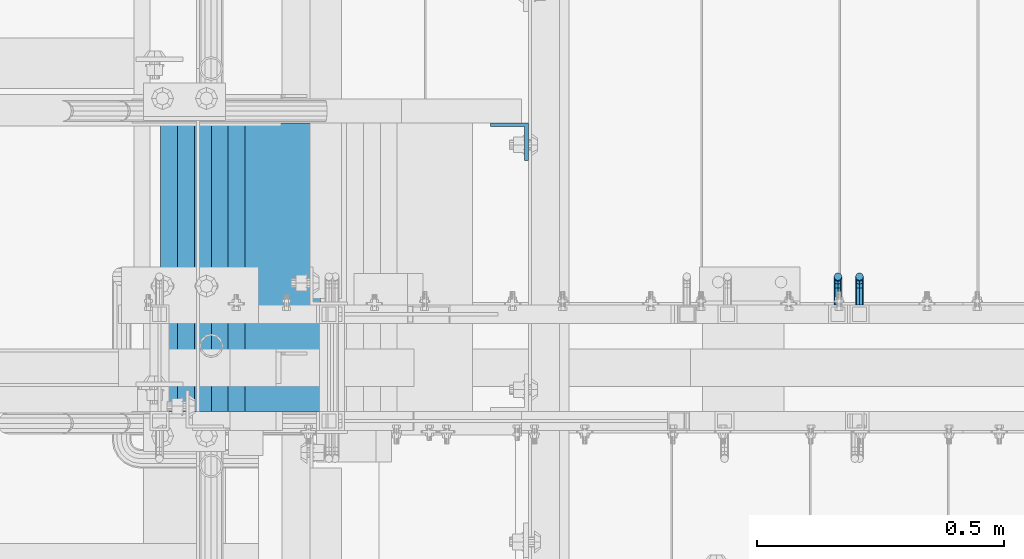
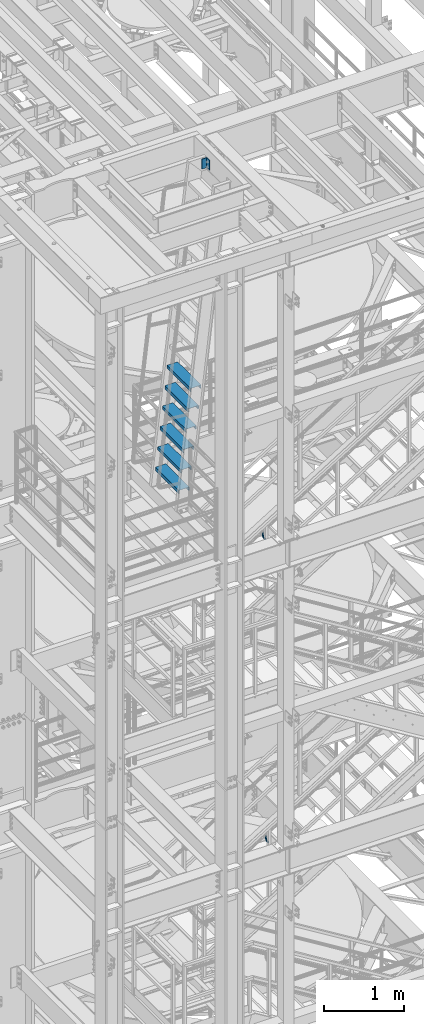
# One storey, part 1169 of 1876: 9 beams, 3 elements without a shape of their own.
"""IFC2X3 building model written with IfcOpenShell, lengths in millimetres."""

from ifc_helpers import new_model, si_unit, frame, origin_with_axes, place, context, subcontext, project, spatial, faceted_brep, material, type_object, element, aggregate, save


model = new_model("IFC2X3")

# Units and contexts
model_context = context("Model", 3, precision=1e-05, world=origin_with_axes())
body_context = subcontext(model_context, "Body", "Model", "MODEL_VIEW")
ifc_project = project(units=[si_unit("LENGTHUNIT", "METRE", prefix="MILLI"), si_unit("AREAUNIT", "SQUARE_METRE"), si_unit("VOLUMEUNIT", "CUBIC_METRE"), si_unit("MASSUNIT", "GRAM", prefix="KILO"), si_unit("TIMEUNIT", "SECOND"), si_unit("PLANEANGLEUNIT", "RADIAN"), si_unit("SOLIDANGLEUNIT", "STERADIAN"), si_unit("THERMODYNAMICTEMPERATUREUNIT", "DEGREE_CELSIUS"), si_unit("LUMINOUSINTENSITYUNIT", "LUMEN")], contexts=[model_context])

# Site, building, storey
site_placement = place(None, origin_with_axes())
site = spatial("IfcSite", under=ifc_project, at=site_placement, CompositionType="ELEMENT")
building_placement = place(site_placement, origin_with_axes())
building = spatial("IfcBuilding", under=site, at=building_placement, Name="Undefined", CompositionType="ELEMENT")
storey_placement = place(building_placement, origin_with_axes())
storey = spatial("IfcBuildingStorey", under=building, at=storey_placement, Name="Undefined", CompositionType="ELEMENT", Elevation=0.0)

# Assembly, beam
assembly_1_placement = place(storey_placement, origin_with_axes())
assembly_1 = element("IfcElementAssembly", 1, at=assembly_1_placement, inside=storey, Name="RAIL", AssemblyPlace="NOTDEFINED", PredefinedType="RIGID_FRAME")
ifc_material = material(Name="STEEL/A36")
beam_type_1 = type_object("IfcBeamType", PredefinedType="NOTDEFINED")
beam_1_placement = place(assembly_1_placement, frame((3092.45000026398, -5715.00000114554, 12296.9866319821), z_axis=(1.0, 0.0, 0.0), x_axis=(0.0, 1.0, 0.0)))
beam_1 = element("IfcBeam", 2, at=beam_1_placement, type_object=beam_type_1, material=ifc_material, Name="BRACKET", context=body_context, shape_type="Brep", body=[
    faceted_brep([(0.0, -5.61266007566822, 5.61266007566883), (0.0, 0.0, 7.9375), (0.0, 5.61266007566822, 5.61266007566883), (0.0, 7.9375, 0.0), (0.0, 5.61266007566822, -5.61266007566883), (0.0, 0.0, -7.9375), (0.0, -5.61266007566822, -5.61266007566883), (0.0, -7.9375, 0.0), (23.8125, -5.61266007566883, -5.61266007566792), (23.8125, -7.9375, 0.0), (23.8125, -5.61266007566883, 5.61266007566792), (23.8125, 0.0, 7.9375), (23.8125, 5.61266007566883, 5.61266007566792), (23.8125, 7.9375, 0.0), (23.8125, 5.61266007566883, -5.61266007566792), (23.8125, 0.0, -7.9375), (36.5702095103998, 2.53766620105671, -7.9375), (38.7180815328556, -2.64775556579843, -5.61266007566792), (39.6077592547981, -4.79562758825341, 0.0), (38.7180815328556, -2.64775556579843, 5.61266007566792), (36.5702095103998, 2.53766620105671, 7.9375), (34.4223374879448, 7.72308796790821, 5.61266007566792), (33.5326597660023, 9.87095999036319, 0.0), (34.4223374879448, 7.72308796790821, -5.61266007566792), (43.4169233967659, 13.733078129113, -5.61266007566792), (47.3856733967659, 9.76432812911298, -7.9375), (41.773013321098, 15.3769882047818, 0.0), (43.4169233967659, 13.733078129113, 5.61266007566792), (47.3856733967659, 9.76432812911298, 7.9375), (51.3544233967659, 5.79557812911298, 5.61266007566792), (52.9983334724348, 4.15166805344415, 0.0), (51.3544233967659, 5.79557812911298, -5.61266007566792), (54.6123353248231, 20.5797920154801, -7.9375), (59.7977570916764, 18.4319199930251, -5.61266007566792), (49.4269135579698, 22.727664037935, -5.61266007566792), (47.2790415355148, 23.6173417598766, 0.0), (49.4269135579698, 22.727664037935, 5.61266007566792), (54.6123353248231, 20.5797920154801, 7.9375), (59.7977570916764, 18.4319199930251, 5.61266007566792), (61.9456291141314, 17.5422422710835, 0.0), (62.7626616015468, 33.3375015258789, -5.61266007566792), (65.0875015258789, 33.3375015258789, 0.0), (57.1500015258789, 33.3375015258789, -7.9375), (51.5373414502101, 33.3375015258789, -5.61266007566792), (49.2125015258789, 33.3375015258789, 0.0), (51.5373414502101, 33.3375015258789, 5.61266007566792), (57.1500015258789, 33.3375015258789, 7.9375), (62.7626616015468, 33.3375015258789, 5.61266007566792), (65.0875015258789, 66.6490606416592, 0.0), (62.7626616015468, 70.1016967070464, 5.61266007566792), (57.1500015258789, 71.5318253912683, 7.9375), (51.537341450211, 70.1016967070464, 5.61266007566792), (49.2125015258789, 66.6490606416592, 0.0), (51.537341450211, 63.1964245762738, -5.61266007566792), (57.1500015258789, 61.7662958920519, -7.9375), (62.7626616015468, 63.1964245762738, -5.61266007566792)], [[[0, 1, 2, 3, 4, 5, 6, 7]], [[7, 6, 8, 9]], [[0, 7, 9, 10]], [[1, 0, 10, 11]], [[2, 1, 11, 12]], [[3, 2, 12, 13]], [[4, 3, 13, 14]], [[5, 4, 14, 15]], [[6, 5, 15, 8]], [[8, 15, 16, 17]], [[9, 8, 17, 18]], [[10, 9, 18, 19]], [[11, 10, 19, 20]], [[12, 11, 20, 21]], [[13, 12, 21, 22]], [[14, 13, 22, 23]], [[15, 14, 23, 16]], [[23, 24, 25, 16]], [[22, 26, 24, 23]], [[21, 27, 26, 22]], [[20, 28, 27, 21]], [[19, 29, 28, 20]], [[18, 30, 29, 19]], [[17, 31, 30, 18]], [[16, 25, 31, 17]], [[25, 32, 33, 31]], [[24, 34, 32, 25]], [[26, 35, 34, 24]], [[27, 36, 35, 26]], [[28, 37, 36, 27]], [[29, 38, 37, 28]], [[30, 39, 38, 29]], [[31, 33, 39, 30]], [[33, 40, 41, 39]], [[32, 42, 40, 33]], [[34, 43, 42, 32]], [[35, 44, 43, 34]], [[36, 45, 44, 35]], [[37, 46, 45, 36]], [[38, 47, 46, 37]], [[39, 41, 47, 38]], [[47, 41, 48, 49]], [[46, 47, 49, 50]], [[45, 46, 50, 51]], [[44, 45, 51, 52]], [[43, 44, 52, 53]], [[42, 43, 53, 54]], [[40, 42, 54, 55]], [[41, 40, 55, 48]], [[54, 53, 52, 51, 50, 49, 48, 55]]]),
])
aggregate(assembly_1, [beam_1])

assembly_2_placement = place(storey_placement, origin_with_axes())
assembly_2 = element("IfcElementAssembly", 3, at=assembly_2_placement, inside=storey, Name="RAIL", AssemblyPlace="NOTDEFINED", PredefinedType="RIGID_FRAME")
beam_2_placement = place(assembly_2_placement, frame((3048.79374922798, -5715.00000114554, 16930.3935489167), z_axis=(1.0, 0.0, 0.0), x_axis=(0.0, 1.0, 0.0)))
beam_2 = element("IfcBeam", 4, at=beam_2_placement, type_object=beam_type_1, material=ifc_material, Name="BRACKET", context=body_context, shape_type="Brep", body=[
    faceted_brep([(0.0, -5.61266007566822, 5.61266007566883), (0.0, 0.0, 7.9375), (0.0, 5.61266007566822, 5.61266007566883), (0.0, 7.9375, 0.0), (0.0, 5.61266007566822, -5.61266007566883), (0.0, 0.0, -7.9375), (0.0, -5.61266007566822, -5.61266007566883), (0.0, -7.9375, 0.0), (23.8125, -5.61266007566883, -5.61266007566792), (23.8125, -7.9375, 0.0), (23.8125, -5.61266007566883, 5.61266007566792), (23.8125, 0.0, 7.9375), (23.8125, 5.61266007566883, 5.61266007566792), (23.8125, 7.9375, 0.0), (23.8125, 5.61266007566883, -5.61266007566792), (23.8125, 0.0, -7.9375), (36.5702095103998, 2.53766620105671, -7.9375), (38.7180815328556, -2.64775556579843, -5.61266007566792), (39.6077592547981, -4.79562758825341, 0.0), (38.7180815328556, -2.64775556579843, 5.61266007566792), (36.5702095103998, 2.53766620105671, 7.9375), (34.4223374879448, 7.72308796790821, 5.61266007566792), (33.5326597660023, 9.87095999036319, 0.0), (34.4223374879448, 7.72308796790821, -5.61266007566792), (43.4169233967659, 13.733078129113, -5.61266007566792), (47.3856733967659, 9.76432812911298, -7.9375), (41.773013321098, 15.3769882047818, 0.0), (43.4169233967659, 13.733078129113, 5.61266007566792), (47.3856733967659, 9.76432812911298, 7.9375), (51.3544233967659, 5.79557812911298, 5.61266007566792), (52.9983334724348, 4.15166805344415, 0.0), (51.3544233967659, 5.79557812911298, -5.61266007566792), (54.6123353248231, 20.5797920154801, -7.9375), (59.7977570916764, 18.4319199930251, -5.61266007566792), (49.4269135579698, 22.727664037935, -5.61266007566792), (47.2790415355148, 23.6173417598766, 0.0), (49.4269135579698, 22.727664037935, 5.61266007566792), (54.6123353248231, 20.5797920154801, 7.9375), (59.7977570916764, 18.4319199930251, 5.61266007566792), (61.9456291141314, 17.5422422710835, 0.0), (62.7626616015468, 33.3375015258789, -5.61266007566792), (65.0875015258789, 33.3375015258789, 0.0), (57.1500015258789, 33.3375015258789, -7.9375), (51.5373414502101, 33.3375015258789, -5.61266007566792), (49.2125015258789, 33.3375015258789, 0.0), (51.5373414502101, 33.3375015258789, 5.61266007566792), (57.1500015258789, 33.3375015258789, 7.9375), (62.7626616015468, 33.3375015258789, 5.61266007566792), (65.0875015258789, 66.4903820289292, 0.0), (62.7626616015468, 69.9676002640044, 5.61266007566837), (57.1500015258789, 71.4079051966655, 7.9375), (51.537341450211, 69.9676002640044, 5.61266007566837), (49.2125015258789, 66.4903820289292, 0.0), (51.537341450211, 63.0131928592527, -5.61266007566837), (57.1500015258789, 61.5728879265953, -7.9375), (62.7626616015468, 63.0131928592527, -5.61266007566837)], [[[0, 1, 2, 3, 4, 5, 6, 7]], [[7, 6, 8, 9]], [[0, 7, 9, 10]], [[1, 0, 10, 11]], [[2, 1, 11, 12]], [[3, 2, 12, 13]], [[4, 3, 13, 14]], [[5, 4, 14, 15]], [[6, 5, 15, 8]], [[8, 15, 16, 17]], [[9, 8, 17, 18]], [[10, 9, 18, 19]], [[11, 10, 19, 20]], [[12, 11, 20, 21]], [[13, 12, 21, 22]], [[14, 13, 22, 23]], [[15, 14, 23, 16]], [[23, 24, 25, 16]], [[22, 26, 24, 23]], [[21, 27, 26, 22]], [[20, 28, 27, 21]], [[19, 29, 28, 20]], [[18, 30, 29, 19]], [[17, 31, 30, 18]], [[16, 25, 31, 17]], [[25, 32, 33, 31]], [[24, 34, 32, 25]], [[26, 35, 34, 24]], [[27, 36, 35, 26]], [[28, 37, 36, 27]], [[29, 38, 37, 28]], [[30, 39, 38, 29]], [[31, 33, 39, 30]], [[33, 40, 41, 39]], [[32, 42, 40, 33]], [[34, 43, 42, 32]], [[35, 44, 43, 34]], [[36, 45, 44, 35]], [[37, 46, 45, 36]], [[38, 47, 46, 37]], [[39, 41, 47, 38]], [[47, 41, 48, 49]], [[46, 47, 49, 50]], [[45, 46, 50, 51]], [[44, 45, 51, 52]], [[43, 44, 52, 53]], [[42, 43, 53, 54]], [[40, 42, 54, 55]], [[41, 40, 55, 48]], [[54, 53, 52, 51, 50, 49, 48, 55]]]),
])
aggregate(assembly_2, [beam_2])

# Assembly, beams
assembly_3_placement = place(storey_placement, origin_with_axes())
assembly_3 = element("IfcElementAssembly", 5, at=assembly_3_placement, inside=storey, Name="RIGHT STRINGER", AssemblyPlace="NOTDEFINED", PredefinedType="RIGID_FRAME")
beam_type_2 = type_object("IfcBeamType", PredefinedType="NOTDEFINED")
beam_3_placement = place(assembly_3_placement, frame((1925.98765681836, -5930.9, 19748.5), z_axis=(1.0, 0.0, 0.0), x_axis=(0.0, 1.0, 0.0)))
beam_3 = element("IfcBeam", 6, at=beam_3_placement, type_object=beam_type_2, material=ifc_material, Name="TREAD", context=body_context, shape_type="Brep", body=[
    faceted_brep([(0.0, -25.4000000000015, -76.1999999999998), (0.0, 25.4000000000015, -76.1999999999998), (584.199999999999, 25.4000000000015, -76.1999999999998), (584.199999999999, -25.4000000000015, -76.1999999999998), (0.0, 25.4000000000015, 76.1999999999998), (584.199999999999, 25.4000000000015, 76.1999999999998), (0.0, -25.4000000000015, 76.1999999999998), (584.199999999999, -25.4000000000015, 76.1999999999998), (0.0, -25.4000000000015, 63.5), (584.199999999999, -25.4000000000015, 63.5), (0.0, -22.2249999999985, 63.5), (584.199999999999, -22.2249999999985, 63.5), (0.0, -22.2249999999985, 73.0250000000001), (584.199999999999, -22.2249999999985, 73.0250000000001), (0.0, 22.2249999999985, 73.0250000000001), (584.199999999999, 22.2249999999985, 73.0250000000001), (0.0, 22.2249999999985, -73.0250000000001), (584.199999999999, 22.2249999999985, -73.0250000000001), (0.0, -22.2249999999985, -73.0250000000001), (584.199999999999, -22.2249999999985, -73.0250000000001), (0.0, -22.2249999999985, -63.5), (584.199999999999, -22.2249999999985, -63.5), (0.0, -25.4000000000015, -63.5), (584.199999999999, -25.4000000000015, -63.5)], [[[0, 1, 2, 3]], [[1, 4, 5, 2]], [[4, 6, 7, 5]], [[6, 8, 9, 7]], [[8, 10, 11, 9]], [[10, 12, 13, 11]], [[12, 14, 15, 13]], [[14, 16, 17, 15]], [[16, 18, 19, 17]], [[18, 20, 21, 19]], [[20, 22, 23, 21]], [[22, 0, 3, 23]], [[5, 7, 9, 11, 13, 15, 17, 19, 21, 23, 3, 2]], [[22, 20, 18, 16, 14, 12, 10, 8, 6, 4, 1, 0]]]),
])
beam_4_placement = place(assembly_3_placement, frame((1891.79804734863, -5930.9, 19450.05), z_axis=(1.0, 0.0, 0.0), x_axis=(0.0, 1.0, 0.0)))
beam_4 = element("IfcBeam", 7, at=beam_4_placement, type_object=beam_type_2, material=ifc_material, Name="TREAD", context=body_context, shape_type="Brep", body=[
    faceted_brep([(0.0, -25.4000000000015, -76.1999999999998), (0.0, 25.4000000000015, -76.1999999999998), (584.199999999999, 25.4000000000015, -76.1999999999998), (584.199999999999, -25.4000000000015, -76.1999999999998), (0.0, 25.4000000000015, 76.1999999999998), (584.199999999999, 25.4000000000015, 76.1999999999998), (0.0, -25.4000000000015, 76.1999999999998), (584.199999999999, -25.4000000000015, 76.1999999999998), (0.0, -25.4000000000015, 63.5), (584.199999999999, -25.4000000000015, 63.5), (0.0, -22.2249999999985, 63.5), (584.199999999999, -22.2249999999985, 63.5), (0.0, -22.2249999999985, 73.0250000000001), (584.199999999999, -22.2249999999985, 73.0250000000001), (0.0, 22.2249999999985, 73.0250000000001), (584.199999999999, 22.2249999999985, 73.0250000000001), (0.0, 22.2249999999985, -73.0250000000001), (584.199999999999, 22.2249999999985, -73.0250000000001), (0.0, -22.2249999999985, -73.0250000000001), (584.199999999999, -22.2249999999985, -73.0250000000001), (0.0, -22.2249999999985, -63.5), (584.199999999999, -22.2249999999985, -63.5), (0.0, -25.4000000000015, -63.5), (584.199999999999, -25.4000000000015, -63.5)], [[[0, 1, 2, 3]], [[1, 4, 5, 2]], [[4, 6, 7, 5]], [[6, 8, 9, 7]], [[8, 10, 11, 9]], [[10, 12, 13, 11]], [[12, 14, 15, 13]], [[14, 16, 17, 15]], [[16, 18, 19, 17]], [[18, 20, 21, 19]], [[20, 22, 23, 21]], [[22, 0, 3, 23]], [[5, 7, 9, 11, 13, 15, 17, 19, 21, 23, 3, 2]], [[22, 20, 18, 16, 14, 12, 10, 8, 6, 4, 1, 0]]]),
])
beam_5_placement = place(assembly_3_placement, frame((1857.6084378789, -5930.9, 19151.6), z_axis=(1.0, 0.0, 0.0), x_axis=(0.0, 1.0, 0.0)))
beam_5 = element("IfcBeam", 8, at=beam_5_placement, type_object=beam_type_2, material=ifc_material, Name="TREAD", context=body_context, shape_type="Brep", body=[
    faceted_brep([(0.0, -25.4000000000015, -76.1999999999998), (0.0, 25.4000000000015, -76.1999999999998), (584.199999999999, 25.4000000000015, -76.1999999999998), (584.199999999999, -25.4000000000015, -76.1999999999998), (0.0, 25.4000000000015, 76.1999999999998), (584.199999999999, 25.4000000000015, 76.1999999999998), (0.0, -25.4000000000015, 76.1999999999998), (584.199999999999, -25.4000000000015, 76.1999999999998), (0.0, -25.4000000000015, 63.5), (584.199999999999, -25.4000000000015, 63.5), (0.0, -22.2249999999985, 63.5), (584.199999999999, -22.2249999999985, 63.5), (0.0, -22.2249999999985, 73.0250000000001), (584.199999999999, -22.2249999999985, 73.0250000000001), (0.0, 22.2249999999985, 73.0250000000001), (584.199999999999, 22.2249999999985, 73.0250000000001), (0.0, 22.2249999999985, -73.0250000000001), (584.199999999999, 22.2249999999985, -73.0250000000001), (0.0, -22.2249999999985, -73.0250000000001), (584.199999999999, -22.2249999999985, -73.0250000000001), (0.0, -22.2249999999985, -63.5), (584.199999999999, -22.2249999999985, -63.5), (0.0, -25.4000000000015, -63.5), (584.199999999999, -25.4000000000015, -63.5)], [[[0, 1, 2, 3]], [[1, 4, 5, 2]], [[4, 6, 7, 5]], [[6, 8, 9, 7]], [[8, 10, 11, 9]], [[10, 12, 13, 11]], [[12, 14, 15, 13]], [[14, 16, 17, 15]], [[16, 18, 19, 17]], [[18, 20, 21, 19]], [[20, 22, 23, 21]], [[22, 0, 3, 23]], [[5, 7, 9, 11, 13, 15, 17, 19, 21, 23, 3, 2]], [[22, 20, 18, 16, 14, 12, 10, 8, 6, 4, 1, 0]]]),
])
beam_6_placement = place(assembly_3_placement, frame((1823.41882840918, -5930.9, 18853.15), z_axis=(1.0, 0.0, 0.0), x_axis=(0.0, 1.0, 0.0)))
beam_6 = element("IfcBeam", 9, at=beam_6_placement, type_object=beam_type_2, material=ifc_material, Name="TREAD", context=body_context, shape_type="Brep", body=[
    faceted_brep([(0.0, -25.4000000000015, -76.1999999999998), (0.0, 25.4000000000015, -76.1999999999998), (584.199999999999, 25.4000000000015, -76.1999999999998), (584.199999999999, -25.4000000000015, -76.1999999999998), (0.0, 25.4000000000015, 76.1999999999998), (584.199999999999, 25.4000000000015, 76.1999999999998), (0.0, -25.4000000000015, 76.1999999999998), (584.199999999999, -25.4000000000015, 76.1999999999998), (0.0, -25.4000000000015, 63.5), (584.199999999999, -25.4000000000015, 63.5), (0.0, -22.2249999999985, 63.5), (584.199999999999, -22.2249999999985, 63.5), (0.0, -22.2249999999985, 73.0250000000001), (584.199999999999, -22.2249999999985, 73.0250000000001), (0.0, 22.2249999999985, 73.0250000000001), (584.199999999999, 22.2249999999985, 73.0250000000001), (0.0, 22.2249999999985, -73.0250000000001), (584.199999999999, 22.2249999999985, -73.0250000000001), (0.0, -22.2249999999985, -73.0250000000001), (584.199999999999, -22.2249999999985, -73.0250000000001), (0.0, -22.2249999999985, -63.5), (584.199999999999, -22.2249999999985, -63.5), (0.0, -25.4000000000015, -63.5), (584.199999999999, -25.4000000000015, -63.5)], [[[0, 1, 2, 3]], [[1, 4, 5, 2]], [[4, 6, 7, 5]], [[6, 8, 9, 7]], [[8, 10, 11, 9]], [[10, 12, 13, 11]], [[12, 14, 15, 13]], [[14, 16, 17, 15]], [[16, 18, 19, 17]], [[18, 20, 21, 19]], [[20, 22, 23, 21]], [[22, 0, 3, 23]], [[5, 7, 9, 11, 13, 15, 17, 19, 21, 23, 3, 2]], [[22, 20, 18, 16, 14, 12, 10, 8, 6, 4, 1, 0]]]),
])
beam_7_placement = place(assembly_3_placement, frame((1789.22921893945, -5930.9, 18554.7), z_axis=(1.0, 0.0, 0.0), x_axis=(0.0, 1.0, 0.0)))
beam_7 = element("IfcBeam", 10, at=beam_7_placement, type_object=beam_type_2, material=ifc_material, Name="TREAD", context=body_context, shape_type="Brep", body=[
    faceted_brep([(0.0, -25.4000000000015, -76.1999999999998), (0.0, 25.4000000000015, -76.1999999999998), (584.199999999999, 25.4000000000015, -76.1999999999998), (584.199999999999, -25.4000000000015, -76.1999999999998), (0.0, 25.4000000000015, 76.1999999999998), (584.199999999999, 25.4000000000015, 76.1999999999998), (0.0, -25.4000000000015, 76.1999999999998), (584.199999999999, -25.4000000000015, 76.1999999999998), (0.0, -25.4000000000015, 63.5), (584.199999999999, -25.4000000000015, 63.5), (0.0, -22.2249999999985, 63.5), (584.199999999999, -22.2249999999985, 63.5), (0.0, -22.2249999999985, 73.0250000000001), (584.199999999999, -22.2249999999985, 73.0250000000001), (0.0, 22.2249999999985, 73.0250000000001), (584.199999999999, 22.2249999999985, 73.0250000000001), (0.0, 22.2249999999985, -73.0250000000001), (584.199999999999, 22.2249999999985, -73.0250000000001), (0.0, -22.2249999999985, -73.0250000000001), (584.199999999999, -22.2249999999985, -73.0250000000001), (0.0, -22.2249999999985, -63.5), (584.199999999999, -22.2249999999985, -63.5), (0.0, -25.4000000000015, -63.5), (584.199999999999, -25.4000000000015, -63.5)], [[[0, 1, 2, 3]], [[1, 4, 5, 2]], [[4, 6, 7, 5]], [[6, 8, 9, 7]], [[8, 10, 11, 9]], [[10, 12, 13, 11]], [[12, 14, 15, 13]], [[14, 16, 17, 15]], [[16, 18, 19, 17]], [[18, 20, 21, 19]], [[20, 22, 23, 21]], [[22, 0, 3, 23]], [[5, 7, 9, 11, 13, 15, 17, 19, 21, 23, 3, 2]], [[22, 20, 18, 16, 14, 12, 10, 8, 6, 4, 1, 0]]]),
])
beam_8_placement = place(assembly_3_placement, frame((1755.03960946973, -5930.9, 18256.25), z_axis=(1.0, 0.0, 0.0), x_axis=(0.0, 1.0, 0.0)))
beam_8 = element("IfcBeam", 11, at=beam_8_placement, type_object=beam_type_2, material=ifc_material, Name="TREAD", context=body_context, shape_type="Brep", body=[
    faceted_brep([(0.0, -25.4000000000015, -76.1999999999998), (0.0, 25.4000000000015, -76.1999999999998), (584.199999999999, 25.4000000000015, -76.1999999999998), (584.199999999999, -25.4000000000015, -76.1999999999998), (0.0, 25.4000000000015, 76.1999999999998), (584.199999999999, 25.4000000000015, 76.1999999999998), (0.0, -25.4000000000015, 76.1999999999998), (584.199999999999, -25.4000000000015, 76.1999999999998), (0.0, -25.4000000000015, 63.5), (584.199999999999, -25.4000000000015, 63.5), (0.0, -22.2249999999985, 63.5), (584.199999999999, -22.2249999999985, 63.5), (0.0, -22.2249999999985, 73.0250000000001), (584.199999999999, -22.2249999999985, 73.0250000000001), (0.0, 22.2249999999985, 73.0250000000001), (584.199999999999, 22.2249999999985, 73.0250000000001), (0.0, 22.2249999999985, -73.0250000000001), (584.199999999999, 22.2249999999985, -73.0250000000001), (0.0, -22.2249999999985, -73.0250000000001), (584.199999999999, -22.2249999999985, -73.0250000000001), (0.0, -22.2249999999985, -63.5), (584.199999999999, -22.2249999999985, -63.5), (0.0, -25.4000000000015, -63.5), (584.199999999999, -25.4000000000015, -63.5)], [[[0, 1, 2, 3]], [[1, 4, 5, 2]], [[4, 6, 7, 5]], [[6, 8, 9, 7]], [[8, 10, 11, 9]], [[10, 12, 13, 11]], [[12, 14, 15, 13]], [[14, 16, 17, 15]], [[16, 18, 19, 17]], [[18, 20, 21, 19]], [[20, 22, 23, 21]], [[22, 0, 3, 23]], [[5, 7, 9, 11, 13, 15, 17, 19, 21, 23, 3, 2]], [[22, 20, 18, 16, 14, 12, 10, 8, 6, 4, 1, 0]]]),
])
beam_type_3 = type_object("IfcBeamType", Name="L3X3X5/16", PredefinedType="NOTDEFINED")
beam_9_placement = place(assembly_3_placement, frame((2384.425, -5384.80000000001, 22742.525), z_axis=(0.0, -1.0, 0.0), x_axis=(0.0, 0.0, -1.0)))
beam_9 = element("IfcBeam", 12, at=beam_9_placement, type_object=beam_type_3, material=ifc_material, Name="ANGLE", ObjectType="L3X3X5/16", context=body_context, shape_type="Brep", body=[
    faceted_brep([(0.0, 38.1000000000004, -38.1), (0.0, 38.1000000000004, 38.1), (152.4, 38.1000000000004, 38.1), (152.4, 38.1000000000004, -38.1), (0.0, 30.1625, 38.1000000000004), (152.400000000001, 30.1624999999999, 38.1000000000004), (0.0, 30.1625, -30.1625000000004), (152.400000000001, 30.1624999999999, -30.1625000000004), (0.0, -38.1, -30.1625000000004), (152.400000000001, -38.0999999999999, -30.1625000000004), (0.0, -38.1000000000004, -38.1), (152.4, -38.1000000000004, -38.1)], [[[0, 1, 2, 3]], [[1, 4, 5, 2]], [[4, 6, 7, 5]], [[6, 8, 9, 7]], [[8, 10, 11, 9]], [[10, 0, 3, 11]], [[5, 7, 9, 11, 3, 2]], [[10, 8, 6, 4, 1, 0]]]),
])
aggregate(assembly_3, [beam_9, beam_3, beam_4, beam_5, beam_6, beam_7, beam_8])

save(model, "model.ifc")
